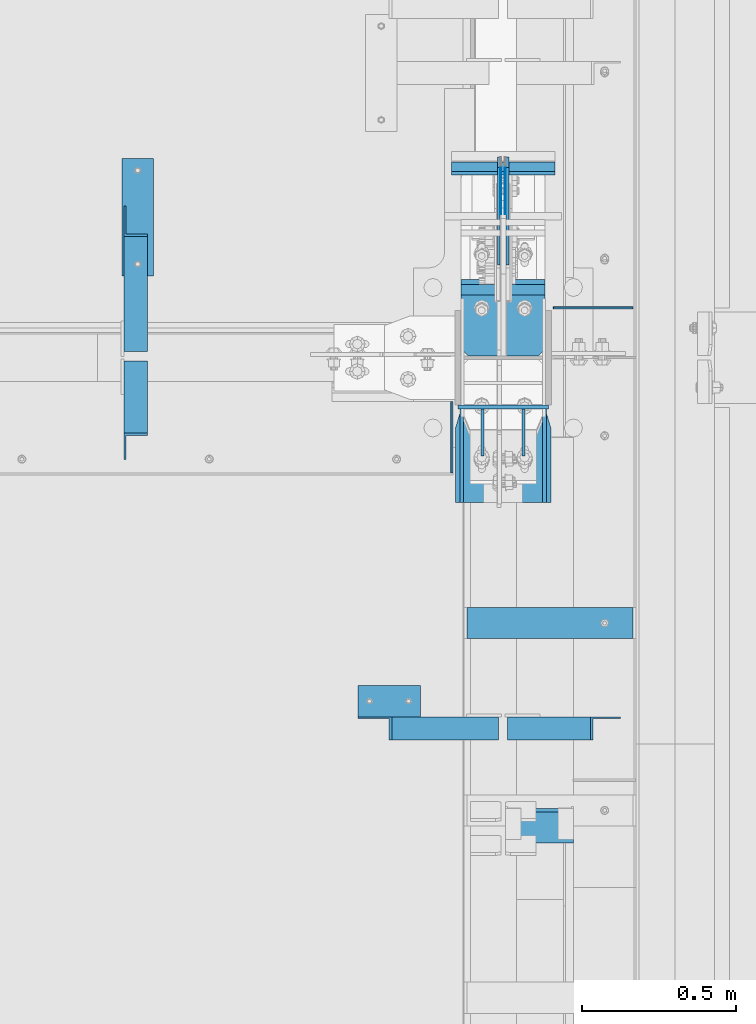
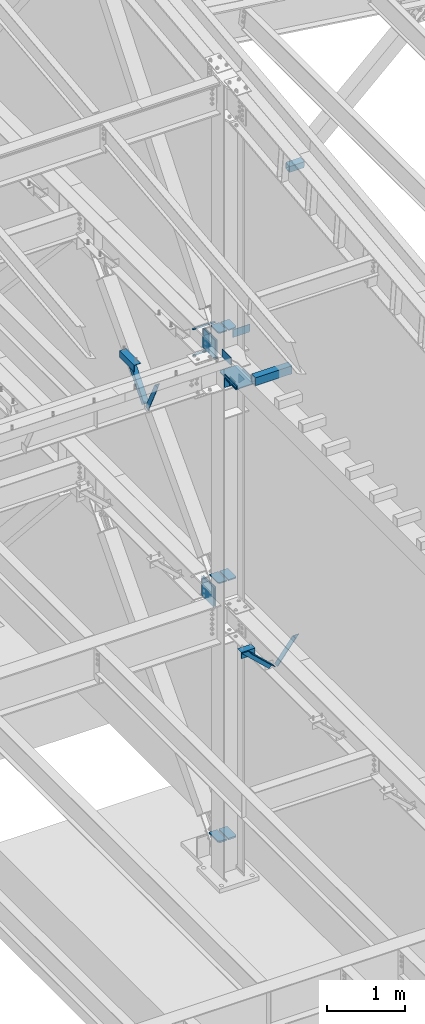
# One storey, part 843 of 1179: 26 beams, 4 members, 17 elements without a shape of their own.
"""IFC2X3 building model written with IfcOpenShell, lengths in millimetres."""

from ifc_helpers import new_model, si_unit, frame, origin_with_axes, place, context, subcontext, project, spatial, faceted_brep, material, type_object, element, aggregate, save


model = new_model("IFC2X3")

# Units and contexts
model_context = context("Model", 3, precision=1e-05, world=origin_with_axes())
body_context = subcontext(model_context, "Body", "Model", "MODEL_VIEW")
ifc_project = project(units=[si_unit("LENGTHUNIT", "METRE", prefix="MILLI"), si_unit("AREAUNIT", "SQUARE_METRE"), si_unit("VOLUMEUNIT", "CUBIC_METRE"), si_unit("MASSUNIT", "GRAM", prefix="KILO"), si_unit("TIMEUNIT", "SECOND"), si_unit("PLANEANGLEUNIT", "RADIAN"), si_unit("SOLIDANGLEUNIT", "STERADIAN"), si_unit("THERMODYNAMICTEMPERATUREUNIT", "DEGREE_CELSIUS"), si_unit("LUMINOUSINTENSITYUNIT", "LUMEN")], contexts=[model_context])

# Site, building, storey
site_placement = place(None, origin_with_axes())
site = spatial("IfcSite", under=ifc_project, at=site_placement, CompositionType="ELEMENT")
building_placement = place(site_placement, origin_with_axes())
building = spatial("IfcBuilding", under=site, at=building_placement, Name="Undefined", CompositionType="ELEMENT")
storey_placement = place(building_placement, origin_with_axes())
storey = spatial("IfcBuildingStorey", under=building, at=storey_placement, Name="Undefined", CompositionType="ELEMENT", Elevation=0.0)

# Assembly, member
assembly_1_placement = place(storey_placement, origin_with_axes())
assembly_1 = element("IfcElementAssembly", 1, at=assembly_1_placement, inside=storey, Name="ANGLE", AssemblyPlace="NOTDEFINED", PredefinedType="RIGID_FRAME")
ifc_material_1 = material(Name="STEEL/A36")
member_type = type_object("IfcMemberType", Name="L3X3X1/4", PredefinedType="NOTDEFINED")
member_1_placement = place(assembly_1_placement, frame((23112.4124995918, 27508.2, 8013.7), z_axis=(0.0, 0.7672237920886, -0.641379492074067), x_axis=(0.0, -0.641379492074066, -0.767223792088601)))
member_1 = element("IfcMember", 2, at=member_1_placement, type_object=member_type, material=ifc_material_1, Name="ANGLE", ObjectType="L3X3X1/4", context=body_context, shape_type="Brep", body=[
    faceted_brep([(52.5421123063024, 38.0999999999985, -38.0999999999967), (-11.159141226166, 38.0999999999985, 38.1000000000095), (634.651401994255, 38.0999999999985, 38.1000000003041), (634.651401994233, 38.0999999999985, -38.0999999997293), (-11.159141226166, 31.75, 38.1000000000095), (634.651401994255, 31.75, 38.1000000003041), (47.2336745119283, 31.75, -31.7499999999982), (634.651401994237, 31.75, -31.7499999997272), (47.2336745119283, -38.0999999999985, -31.7499999999982), (634.651401994237, -38.0999999999985, -31.7499999997272), (52.5421123063024, -38.0999999999985, -38.0999999999967), (634.651401994233, -38.0999999999985, -38.0999999997293)], [[[0, 1, 2, 3]], [[1, 4, 5, 2]], [[4, 6, 7, 5]], [[6, 8, 9, 7]], [[8, 10, 11, 9]], [[10, 0, 3, 11]], [[5, 7, 9, 11, 3, 2]], [[10, 8, 6, 4, 1, 0]]]),
])
aggregate(assembly_1, [member_1])

assembly_2_placement = place(storey_placement, origin_with_axes())
assembly_2 = element("IfcElementAssembly", 3, at=assembly_2_placement, inside=storey, Name="ANGLE", AssemblyPlace="NOTDEFINED", PredefinedType="RIGID_FRAME")
member_2_placement = place(assembly_2_placement, frame((23112.4124995918, 27005.4961357473, 7519.97080646429), z_axis=(0.0, -0.897509848200057, -0.440994413098296), x_axis=(0.0, -0.440994413098296, 0.897509848200057)))
member_2 = element("IfcMember", 4, at=member_2_placement, type_object=member_type, material=ifc_material_1, Name="ANGLE", ObjectType="L3X3X1/4", context=body_context, shape_type="Brep", body=[
    faceted_brep([(0.0, 38.0999999999985, -38.0999999999999), (0.0, 38.0999999999985, 38.0999999999999), (568.830616953598, 38.0999999999985, 38.0999999992709), (531.389496563324, 38.0999999999985, -38.1000000007189), (0.0, 31.75, 38.1000000000004), (568.830616953598, 31.75, 38.0999999992709), (0.0, 31.75, -31.75), (534.509589929181, 31.75, -31.7500000007203), (0.0, -38.0999999999985, -31.75), (534.509589929181, -38.0999999999985, -31.7500000007203), (0.0, -38.0999999999985, -38.0999999999999), (531.389496563324, -38.0999999999985, -38.1000000007189)], [[[0, 1, 2, 3]], [[1, 4, 5, 2]], [[4, 6, 7, 5]], [[6, 8, 9, 7]], [[8, 10, 11, 9]], [[10, 0, 3, 11]], [[5, 7, 9, 11, 3, 2]], [[10, 8, 6, 4, 1, 0]]]),
])
aggregate(assembly_2, [member_2])

assembly_3_placement = place(storey_placement, origin_with_axes())
assembly_3 = element("IfcElementAssembly", 5, at=assembly_3_placement, inside=storey, Name="ANGLE", AssemblyPlace="NOTDEFINED", PredefinedType="RIGID_FRAME")
member_3_placement = place(assembly_3_placement, frame((23812.1150890972, 25844.5, 4162.88757791506), z_axis=(0.0, -1.0, 0.0), x_axis=(0.729484494811633, 0.0, -0.683997347823379)))
member_3 = element("IfcMember", 6, at=member_3_placement, type_object=member_type, material=ifc_material_1, Name="ANGLE", ObjectType="L3X3X1/4", context=body_context, shape_type="Brep", body=[
    faceted_brep([(148.072119708857, 38.1000000000204, -38.0999999999985), (148.072119708857, 38.1000000000204, 38.0999999999985), (623.824460863128, 38.1000000000349, 38.0999999999985), (623.824460863128, 38.1000000000349, -38.0999999999985), (141.299832423247, 31.7500000000182, 38.0999999999985), (623.824460863128, 31.7500000000291, 38.0999999999985), (141.299832423247, 31.7500000000182, -31.75), (623.824460863128, 31.7500000000291, -31.75), (66.8046722815307, -38.1000000000095, -31.75), (623.824460863132, -38.0999999999913, -31.75), (66.8046722815307, -38.1000000000095, -38.0999999999985), (623.824460863132, -38.0999999999913, -38.0999999999985)], [[[0, 1, 2, 3]], [[1, 4, 5, 2]], [[4, 6, 7, 5]], [[6, 8, 9, 7]], [[8, 10, 11, 9]], [[10, 0, 3, 11]], [[5, 7, 9, 11, 3, 2]], [[10, 8, 6, 4, 1, 0]]]),
])
aggregate(assembly_3, [member_3])

assembly_4_placement = place(storey_placement, origin_with_axes())
assembly_4 = element("IfcElementAssembly", 7, at=assembly_4_placement, inside=storey, Name="ANGLE", AssemblyPlace="NOTDEFINED", PredefinedType="RIGID_FRAME")
member_4_placement = place(assembly_4_placement, frame((24352.3014298031, 25844.5, 3731.6636484264), z_axis=(0.0, -1.0, 0.0), x_axis=(0.614083067285056, 0.0, 0.789241399366365)))
member_4 = element("IfcMember", 8, at=member_4_placement, type_object=member_type, material=ifc_material_1, Name="ANGLE", ObjectType="L3X3X1/4", context=body_context, shape_type="Brep", body=[
    faceted_brep([(0.0, 38.0999999999985, -38.0999999999999), (0.0, 38.0999999999985, 38.0999999999999), (439.713105507173, 38.1000000000386, 38.0999999999985), (439.713105507173, 38.1000000000386, -38.0999999999985), (0.0, 31.75, 38.1000000000004), (444.653834009747, 31.7500000000473, 38.0999999999985), (0.0, 31.75, -31.75), (444.653834009747, 31.7500000000473, -31.75), (0.0, -38.0999999999985, -31.75), (499.001847538042, -38.0999999998749, -31.75), (0.0, -38.0999999999985, -38.0999999999999), (499.001847538042, -38.0999999998749, -38.0999999999985)], [[[0, 1, 2, 3]], [[1, 4, 5, 2]], [[4, 6, 7, 5]], [[6, 8, 9, 7]], [[8, 10, 11, 9]], [[10, 0, 3, 11]], [[5, 7, 9, 11, 3, 2]], [[10, 8, 6, 4, 1, 0]]]),
])
aggregate(assembly_4, [member_4])

# Assembly, beams
assembly_5_placement = place(storey_placement, origin_with_axes())
assembly_5 = element("IfcElementAssembly", 9, at=assembly_5_placement, inside=storey, Name="BEAM", AssemblyPlace="NOTDEFINED", PredefinedType="RIGID_FRAME")
ifc_material_2 = material(Name="STEEL/A572-GR.50")
beam_type_1 = type_object("IfcBeamType", PredefinedType="NOTDEFINED")
beam_1_placement = place(assembly_5_placement, frame((24307.8000366209, 27677.4467233733, 7589.8375), z_axis=(-1.0, 0.0, 0.0), x_axis=(0.0, -1.0, 0.0)))
beam_1 = element("IfcBeam", 10, at=beam_1_placement, type_object=beam_type_1, material=ifc_material_2, Name="PLATE", context=body_context, shape_type="Brep", body=[
    faceted_brep([(0.0, 4.76249999999982, -168.275000000001), (0.0, 4.76250000000073, 168.275), (31.75, 4.76249999999982, 168.275000000001), (31.75, 4.76249999999982, -168.275000000001), (0.0, -4.76250000000073, 168.275), (31.75, -4.76249999999982, 168.275000000001), (0.0, -4.76249999999982, -168.275000000001), (31.75, -4.76249999999982, -168.275000000001)], [[[0, 1, 2, 3]], [[1, 4, 5, 2]], [[4, 6, 7, 5]], [[6, 0, 3, 7]], [[5, 7, 3, 2]], [[6, 4, 1, 0]]]),
])
beam_2_placement = place(assembly_5_placement, frame((24307.8000366209, 27688.5588209119, 7989.4905), z_axis=(-1.0, 0.0, 0.0), x_axis=(0.0, -1.0, 0.0)))
beam_2 = element("IfcBeam", 11, at=beam_2_placement, type_object=beam_type_1, material=ifc_material_2, Name="PLATE", context=body_context, shape_type="Brep", body=[
    faceted_brep([(0.0, 4.76249999999982, -168.275000000001), (0.0, 4.76250000000073, 168.275), (31.75, 4.76249999999982, 168.275000000001), (31.75, 4.76249999999982, -168.275000000001), (0.0, -4.76250000000073, 168.275), (31.75, -4.76249999999982, 168.275000000001), (0.0, -4.76249999999982, -168.275000000001), (31.75, -4.76249999999982, -168.275000000001)], [[[0, 1, 2, 3]], [[1, 4, 5, 2]], [[4, 6, 7, 5]], [[6, 0, 3, 7]], [[5, 7, 3, 2]], [[6, 4, 1, 0]]]),
])

assembly_6_placement = place(storey_placement, origin_with_axes())
assembly_6 = element("IfcElementAssembly", 12, at=assembly_6_placement, inside=storey, Name="COLUMN", AssemblyPlace="NOTDEFINED", PredefinedType="RIGID_FRAME")
beam_type_2 = type_object("IfcBeamType", PredefinedType="NOTDEFINED")
beam_3_placement = place(assembly_6_placement, frame((24160.1625, 26890.6625, 7616.82500000912), z_axis=(0.0, 0.0, 1.0), x_axis=(1.0, 0.0, 0.0)))
beam_3 = element("IfcBeam", 13, at=beam_3_placement, type_object=beam_type_2, material=ifc_material_1, Name="PLATE", context=body_context, shape_type="Brep", body=[
    faceted_brep([(-7.27595761418343e-12, 6.35000000000036, -76.1999999999971), (0.0, 6.35000000000036, 76.2000000000044), (295.274999999994, 6.34999999999854, 76.2000000000007), (295.274999999994, 6.34999999999854, -76.2000000000007), (0.0, -6.35000000000036, 76.2000000000044), (295.274999999994, -6.34999999999854, 76.2000000000007), (7.27595761418343e-12, -6.35000000000036, -76.1999999999971), (295.274999999994, -6.34999999999854, -76.2000000000007)], [[[0, 1, 2, 3]], [[1, 4, 5, 2]], [[4, 6, 7, 5]], [[6, 0, 3, 7]], [[5, 7, 3, 2]], [[6, 4, 1, 0]]]),
])
beam_type_3 = type_object("IfcBeamType", PredefinedType="NOTDEFINED")
beam_4_placement = place(assembly_6_placement, frame((24381.619, 27288.7322991996, 4353.49928057187), z_axis=(1.0, 0.0, 0.0), x_axis=(0.0, -1.0, 0.0)))
beam_4 = element("IfcBeam", 14, at=beam_4_placement, type_object=beam_type_3, material=ifc_material_2, Name="PLATE", context=body_context, shape_type="Brep", body=[
    faceted_brep([(209.157299199604, -9.52499999999964, 62.7065000000002), (231.382299199602, -9.52499999999964, 40.4815000000017), (231.382299199602, 9.52499999999964, 40.4815000000017), (209.157299199604, 9.52499999999964, 62.7065000000002), (231.382299199602, 9.52499999999964, -62.7065000000002), (6.18456397205591e-11, 9.52499999999964, -62.7065000000084), (0.0, 9.52499999999964, 62.7065000000002), (0.0, -9.52499999999964, 62.7065000000002), (6.18456397205591e-11, -9.52499999999964, -62.7065000000084), (231.382299199602, -9.52499999999964, -62.7065000000002)], [[[0, 1, 2, 3]], [[4, 5, 6, 3, 2]], [[6, 7, 0, 3]], [[7, 8, 9, 1, 0]], [[8, 5, 4, 9]], [[9, 4, 2, 1]], [[8, 7, 6, 5]]]),
])
beam_5_placement = place(assembly_6_placement, frame((24233.981, 27288.7322991996, 4353.49928057187), z_axis=(-1.0, 0.0, 0.0), x_axis=(0.0, -1.0, 0.0)))
beam_5 = element("IfcBeam", 15, at=beam_5_placement, type_object=beam_type_3, material=ifc_material_2, Name="PLATE", context=body_context, shape_type="Brep", body=[
    faceted_brep([(209.157299199604, -9.52499999999964, 62.7065000000002), (231.382299199602, -9.52499999999964, 40.4815000000017), (231.382299199602, 9.52499999999964, 40.4815000000017), (209.157299199604, 9.52499999999964, 62.7065000000002), (231.382299199602, 9.52499999999964, -62.7065000000002), (6.18456397205591e-11, 9.52499999999964, -62.7065000000084), (0.0, 9.52499999999964, 62.7065000000002), (0.0, -9.52499999999964, 62.7065000000002), (6.18456397205591e-11, -9.52499999999964, -62.7065000000084), (231.382299199602, -9.52499999999964, -62.7065000000002)], [[[0, 1, 2, 3]], [[4, 5, 6, 3, 2]], [[6, 7, 0, 3]], [[7, 8, 9, 1, 0]], [[8, 5, 4, 9]], [[9, 4, 2, 1]], [[8, 7, 6, 5]]]),
])
beam_type_4 = type_object("IfcBeamType", PredefinedType="NOTDEFINED")
beam_6_placement = place(assembly_6_placement, frame((24234.775, 27057.35, 8286.54339140945), z_axis=(-1.0, 0.0, 0.0), x_axis=(0.0, 1.0, 0.0)))
beam_6 = element("IfcBeam", 16, at=beam_6_placement, type_object=beam_type_4, material=ifc_material_2, Name="PLATE", context=body_context, shape_type="Brep", body=[
    faceted_brep([(1.81898940354586e-11, -9.52499999999782, 41.2750000000015), (22.2250000000204, -9.525000000006, 63.5), (22.2249999999913, 9.52499999999327, 63.5), (-7.27595761418343e-12, 9.52500000000146, 41.2750000000015), (198.4375, 9.52499999999964, 63.5), (198.4375, 9.52499999999964, -63.5), (0.0, 9.52500000000146, -63.5), (198.4375, -9.52499999999964, 63.5), (0.0, -9.52500000000146, -63.5), (198.4375, -9.52499999999964, -63.5)], [[[0, 1, 2, 3]], [[4, 5, 6, 3, 2]], [[7, 4, 2, 1]], [[8, 9, 7, 1, 0]], [[8, 6, 5, 9]], [[7, 9, 5, 4]], [[6, 8, 0, 3]]]),
])
beam_7_placement = place(assembly_6_placement, frame((24380.825, 27057.35, 8286.54339140945), z_axis=(-1.0, 0.0, 0.0), x_axis=(0.0, 1.0, 0.0)))
beam_7 = element("IfcBeam", 17, at=beam_7_placement, type_object=beam_type_4, material=ifc_material_2, Name="PLATE", context=body_context, shape_type="Brep", body=[
    faceted_brep([(22.2250000000204, -9.525000000006, -63.5), (1.81898940354586e-11, -9.52499999999782, -41.2750000000015), (-7.27595761418343e-12, 9.52500000000146, -41.2750000000015), (22.2249999999913, 9.52499999999327, -63.5), (0.0, 9.52500000000146, 63.5), (198.4375, 9.52499999999964, 63.5), (198.4375, 9.52499999999964, -63.5), (0.0, -9.52500000000146, 63.5), (198.4375, -9.52499999999964, 63.5), (198.4375, -9.52499999999964, -63.5)], [[[0, 1, 2, 3]], [[4, 5, 6, 3, 2]], [[4, 7, 8, 5]], [[9, 8, 7, 1, 0]], [[6, 9, 0, 3]], [[8, 9, 6, 5]], [[7, 4, 2, 1]]]),
])

# Assembly, beam
assembly_7_placement = place(storey_placement, origin_with_axes())
assembly_7 = element("IfcElementAssembly", 18, at=assembly_7_placement, inside=storey, Name="ANGLE", AssemblyPlace="NOTDEFINED", PredefinedType="RIGID_FRAME")
beam_type_5 = type_object("IfcBeamType", Name="L4X4X1/4", PredefinedType="NOTDEFINED")
beam_8_placement = place(assembly_7_placement, frame((23118.7624995918, 27317.6213553416, 7962.9), z_axis=(1.0, 0.0, 0.0), x_axis=(0.0, 1.0, 0.0)))
beam_8 = element("IfcBeam", 19, at=beam_8_placement, type_object=beam_type_5, material=ifc_material_1, Name="ANGLE", ObjectType="L4X4X1/4", context=body_context, shape_type="Brep", body=[
    faceted_brep([(1.90993887372315e-11, 50.8000000000002, -50.8000000000002), (1.90993887372315e-11, 50.8000000000002, 50.8000000000002), (381.0, 50.8000000000002, 50.7999999999993), (381.0, 50.8000000000002, -50.7999999999993), (0.0, 44.4500000000007, 50.8000000000002), (381.0, 44.4499999999998, 50.7999999999993), (0.0, 44.4500000000007, -44.4499999999998), (381.0, 44.4499999999998, -44.4500000000007), (0.0, -50.7999999999993, -44.4499999999998), (381.0, -50.8000000000002, -44.4500000000007), (-1.81898940354586e-11, -50.7999999999997, -50.8000000000002), (381.0, -50.8000000000002, -50.7999999999993)], [[[0, 1, 2, 3]], [[1, 4, 5, 2]], [[4, 6, 7, 5]], [[6, 8, 9, 7]], [[8, 10, 11, 9]], [[10, 0, 3, 11]], [[5, 7, 9, 11, 3, 2]], [[10, 8, 6, 4, 1, 0]]]),
])
aggregate(assembly_7, [beam_8])

assembly_8_placement = place(storey_placement, origin_with_axes())
assembly_8 = element("IfcElementAssembly", 20, at=assembly_8_placement, inside=storey, Name="ANGLE", AssemblyPlace="NOTDEFINED", PredefinedType="RIGID_FRAME")
beam_9_placement = place(assembly_8_placement, frame((23834.8036446584, 25933.4, 4051.3), z_axis=(0.0, 0.0, -1.0), x_axis=(1.0, 0.0, 0.0)))
beam_9 = element("IfcBeam", 21, at=beam_9_placement, type_object=beam_type_5, material=ifc_material_1, Name="ANGLE", ObjectType="L4X4X1/4", context=body_context, shape_type="Brep", body=[
    faceted_brep([(1.90993887372315e-11, 50.8000000000002, -50.8000000000002), (1.90993887372315e-11, 50.8000000000002, 50.8000000000002), (203.200000000001, 50.7999999999993, 50.8000000000002), (203.200000000001, 50.7999999999993, -50.8000000000002), (0.0, 44.4500000000007, 50.8000000000002), (203.200000000001, 44.4500000000007, 50.8000000000002), (0.0, 44.4500000000007, -44.4499999999998), (203.200000000001, 44.4500000000007, -44.4499999999998), (0.0, -50.7999999999993, -44.4499999999998), (203.200000000001, -50.7999999999993, -44.4499999999998), (-1.81898940354586e-11, -50.7999999999997, -50.8000000000002), (203.200000000001, -50.7999999999993, -50.8000000000002)], [[[0, 1, 2, 3]], [[1, 4, 5, 2]], [[4, 6, 7, 5]], [[6, 8, 9, 7]], [[8, 10, 11, 9]], [[10, 0, 3, 11]], [[5, 7, 9, 11, 3, 2]], [[10, 8, 6, 4, 1, 0]]]),
])
aggregate(assembly_8, [beam_9])

assembly_9_placement = place(storey_placement, origin_with_axes())
assembly_9 = element("IfcElementAssembly", 22, at=assembly_9_placement, inside=storey, Name="BEAM", AssemblyPlace="NOTDEFINED", PredefinedType="RIGID_FRAME")
beam_type_6 = type_object("IfcBeamType", PredefinedType="NOTDEFINED")
beam_10_placement = place(assembly_9_placement, frame((24141.113, 26676.35, 8083.55000610352), z_axis=(0.0, 0.0, 1.0), x_axis=(0.0, 1.0, 0.0)))
beam_10 = element("IfcBeam", 23, at=beam_10_placement, type_object=beam_type_6, material=ifc_material_1, Name="PLATE", context=body_context, shape_type="Brep", body=[
    faceted_brep([(0.0, 3.17499999999995, -44.4499999999998), (19.0499999999993, 3.17499999999995, -63.5), (19.0499999999993, -3.17499999999995, -63.5), (0.0, -3.17499999999995, -44.4499999999998), (0.0, 3.17499999999927, 63.5), (231.775012187987, 3.17499999989741, 63.5), (231.775012187987, 3.17499999989741, -63.5), (0.0, -3.17499999999927, 63.5), (231.775012187984, -3.17500000010114, 63.5), (231.775012187984, -3.17500000010114, -63.5)], [[[0, 1, 2, 3]], [[4, 5, 6, 1, 0]], [[4, 7, 8, 5]], [[9, 8, 7, 3, 2]], [[6, 9, 2, 1]], [[8, 9, 6, 5]], [[7, 4, 0, 3]]]),
])
aggregate(assembly_9, [beam_10])

# Beam
beam_type_7 = type_object("IfcBeamType", PredefinedType="NOTDEFINED")
beam_11_placement = place(assembly_5_placement, frame((24300.65625, 27669.5088209119, 7804.15), z_axis=(0.0, 0.0, -1.0), x_axis=(0.0, -1.0, 0.0)))
beam_11 = element("IfcBeam", 24, at=beam_11_placement, type_object=beam_type_7, material=ifc_material_2, Name="PLATE", context=body_context, shape_type="Brep", body=[
    faceted_brep([(0.0, 1.58750000000146, -152.4), (0.0, 1.58750000000146, 152.4), (152.400000000009, 1.58750000000146, 152.4), (152.400000000009, 1.58750000000146, -152.4), (0.0, -1.58750000000146, 152.4), (152.400000000009, -1.58750000000146, 152.4), (0.0, -1.58750000000146, -152.4), (152.400000000009, -1.58750000000146, -152.4)], [[[0, 1, 2, 3]], [[1, 4, 5, 2]], [[4, 6, 7, 5]], [[6, 0, 3, 7]], [[5, 7, 3, 2]], [[6, 4, 1, 0]]]),
])

beam_12_placement = place(assembly_5_placement, frame((24314.94375, 27669.5088209119, 7804.15), z_axis=(0.0, 0.0, -1.0), x_axis=(0.0, -1.0, 0.0)))
beam_12 = element("IfcBeam", 25, at=beam_12_placement, type_object=beam_type_7, material=ifc_material_2, Name="PLATE", context=body_context, shape_type="Brep", body=[
    faceted_brep([(0.0, 1.58750000000146, -152.4), (0.0, 1.58750000000146, 152.4), (152.400000000009, 1.58750000000146, 152.4), (152.400000000009, 1.58750000000146, -152.4), (0.0, -1.58750000000146, 152.4), (152.400000000009, -1.58750000000146, 152.4), (0.0, -1.58750000000146, -152.4), (152.400000000009, -1.58750000000146, -152.4)], [[[0, 1, 2, 3]], [[1, 4, 5, 2]], [[4, 6, 7, 5]], [[6, 0, 3, 7]], [[5, 7, 3, 2]], [[6, 4, 1, 0]]]),
])

beam_type_8 = type_object("IfcBeamType", PredefinedType="NOTDEFINED")
beam_13_placement = place(assembly_5_placement, frame((24471.3125128158, 27212.9249996176, 8085.1375), z_axis=(0.0, 0.0, 1.0), x_axis=(1.0, 0.0, 0.0)))
beam_13 = element("IfcBeam", 26, at=beam_13_placement, type_object=beam_type_8, material=ifc_material_1, Name="PLATE", context=body_context, shape_type="Brep", body=[
    faceted_brep([(258.762494772014, -3.17499999977008, -42.8625000000002), (239.712494772015, -3.17499999978463, -61.9125000000004), (239.712494772011, 3.17500000021391, -61.9125000000004), (258.762494772011, 3.1750000002321, -42.8625000000002), (0.0, 3.17499999999927, -61.9125000000004), (0.0, 3.17499999999927, 61.9125000000004), (258.762494772011, 3.1750000002321, 61.9125000000004), (3.63797880709171e-12, -3.17499999999927, 61.9125000000004), (258.762494772014, -3.17499999977008, 61.9125000000004), (3.63797880709171e-12, -3.17499999999927, -61.9125000000004)], [[[0, 1, 2, 3]], [[4, 5, 6, 3, 2]], [[5, 7, 8, 6]], [[8, 7, 9, 1, 0]], [[9, 4, 2, 1]], [[6, 8, 0, 3]], [[9, 7, 5, 4]]]),
])

aggregate(assembly_5, [beam_1, beam_11, beam_12, beam_13, beam_2])

# Assembly, beam
assembly_10_placement = place(storey_placement, origin_with_axes())
assembly_10 = element("IfcElementAssembly", 27, at=assembly_10_placement, inside=storey, Name="PLATE", AssemblyPlace="NOTDEFINED", PredefinedType="RIGID_FRAME")
beam_type_9 = type_object("IfcBeamType", PredefinedType="NOTDEFINED")
beam_14_placement = place(assembly_10_placement, frame((24293.5125, 27703.683001131, 3892.55), z_axis=(0.0, 0.0, -1.0), x_axis=(0.0, -1.0, 0.0)))
beam_14 = element("IfcBeam", 28, at=beam_14_placement, type_object=beam_type_9, material=ifc_material_2, Name="PLATE", context=body_context, shape_type="Brep", body=[
    faceted_brep([(0.0, 4.76250000000073, -152.4), (0.0, 4.76250000000073, 152.4), (317.5, 4.76250000000073, 152.4), (317.5, 4.76250000000073, -152.4), (0.0, -4.76250000000073, 152.4), (317.5, -4.76250000000073, 152.4), (0.0, -4.76250000000073, -152.4), (317.5, -4.76250000000073, -152.4)], [[[0, 1, 2, 3]], [[1, 4, 5, 2]], [[4, 6, 7, 5]], [[6, 0, 3, 7]], [[5, 7, 3, 2]], [[6, 4, 1, 0]]]),
])
aggregate(assembly_10, [beam_14])

assembly_11_placement = place(storey_placement, origin_with_axes())
assembly_11 = element("IfcElementAssembly", 29, at=assembly_11_placement, inside=storey, Name="PLATE", AssemblyPlace="NOTDEFINED", PredefinedType="RIGID_FRAME")
beam_15_placement = place(assembly_11_placement, frame((24322.0875, 27386.183001131, 3892.55), z_axis=(0.0, 0.0, -1.0), x_axis=(0.0, 1.0, 0.0)))
beam_15 = element("IfcBeam", 30, at=beam_15_placement, type_object=beam_type_9, material=ifc_material_2, Name="PLATE", context=body_context, shape_type="Brep", body=[
    faceted_brep([(0.0, 4.76250000000073, -152.4), (0.0, 4.76250000000073, 152.4), (317.5, 4.76250000000073, 152.4), (317.5, 4.76250000000073, -152.4), (0.0, -4.76250000000073, 152.4), (317.5, -4.76250000000073, 152.4), (0.0, -4.76250000000073, -152.4), (317.5, -4.76250000000073, -152.4)], [[[0, 1, 2, 3]], [[1, 4, 5, 2]], [[4, 6, 7, 5]], [[6, 0, 3, 7]], [[5, 7, 3, 2]], [[6, 4, 1, 0]]]),
])
aggregate(assembly_11, [beam_15])

assembly_12_placement = place(storey_placement, origin_with_axes())
assembly_12 = element("IfcElementAssembly", 31, at=assembly_12_placement, inside=storey, Name="PLATE", AssemblyPlace="NOTDEFINED", PredefinedType="RIGID_FRAME")
beam_16_placement = place(assembly_12_placement, frame((24293.5127863882, 27669.5088209119, 7804.15), z_axis=(0.0, 0.0, -1.0), x_axis=(0.0, -1.0, 0.0)))
beam_16 = element("IfcBeam", 32, at=beam_16_placement, type_object=beam_type_9, material=ifc_material_2, Name="PLATE", context=body_context, shape_type="Brep", body=[
    faceted_brep([(0.0, 4.76250000000073, -152.4), (0.0, 4.76250000000073, 152.4), (317.5, 4.76250000000073, 152.4), (317.5, 4.76250000000073, -152.4), (0.0, -4.76250000000073, 152.4), (317.5, -4.76250000000073, 152.4), (0.0, -4.76250000000073, -152.4), (317.5, -4.76250000000073, -152.4)], [[[0, 1, 2, 3]], [[1, 4, 5, 2]], [[4, 6, 7, 5]], [[6, 0, 3, 7]], [[5, 7, 3, 2]], [[6, 4, 1, 0]]]),
])
aggregate(assembly_12, [beam_16])

assembly_13_placement = place(storey_placement, origin_with_axes())
assembly_13 = element("IfcElementAssembly", 33, at=assembly_13_placement, inside=storey, Name="PLATE", AssemblyPlace="NOTDEFINED", PredefinedType="RIGID_FRAME")
beam_17_placement = place(assembly_13_placement, frame((24322.0872136118, 27352.0088209119, 7804.15), z_axis=(0.0, 0.0, -1.0), x_axis=(0.0, 1.0, 0.0)))
beam_17 = element("IfcBeam", 34, at=beam_17_placement, type_object=beam_type_9, material=ifc_material_2, Name="PLATE", context=body_context, shape_type="Brep", body=[
    faceted_brep([(0.0, 4.76250000000073, -152.4), (0.0, 4.76250000000073, 152.4), (317.5, 4.76250000000073, 152.4), (317.5, 4.76250000000073, -152.4), (0.0, -4.76250000000073, 152.4), (317.5, -4.76250000000073, 152.4), (0.0, -4.76250000000073, -152.4), (317.5, -4.76250000000073, -152.4)], [[[0, 1, 2, 3]], [[1, 4, 5, 2]], [[4, 6, 7, 5]], [[6, 0, 3, 7]], [[5, 7, 3, 2]], [[6, 4, 1, 0]]]),
])
aggregate(assembly_13, [beam_17])

# Beam
beam_type_10 = type_object("IfcBeamType", PredefinedType="NOTDEFINED")
beam_18_placement = place(assembly_6_placement, frame((24172.8625, 26579.5125, 7727.95000000912), z_axis=(0.0, 0.0, 1.0), x_axis=(0.0, 1.0, 0.0)))
beam_18 = element("IfcBeam", 35, at=beam_18_placement, type_object=beam_type_10, material=ifc_material_1, Name="PLATE", context=body_context, shape_type="Brep", body=[
    faceted_brep([(0.0, 6.34999999999854, -19.0499999999993), (0.0, 6.35000000000036, 19.0499999999993), (317.5, 6.34999999999854, 19.0499999999993), (317.5, 6.34999999999854, -19.0499999999993), (0.0, -6.35000000000036, 19.0499999999993), (317.5, -6.34999999999854, 19.0499999999993), (0.0, -6.34999999999854, -19.0499999999993), (317.5, -6.34999999999854, -19.0499999999993)], [[[0, 1, 2, 3]], [[1, 4, 5, 2]], [[4, 6, 7, 5]], [[6, 0, 3, 7]], [[5, 7, 3, 2]], [[6, 4, 1, 0]]]),
])

beam_19_placement = place(assembly_6_placement, frame((24442.7375, 26579.5125, 7727.95000000912), z_axis=(0.0, 0.0, 1.0), x_axis=(0.0, 1.0, 0.0)))
beam_19 = element("IfcBeam", 36, at=beam_19_placement, type_object=beam_type_10, material=ifc_material_1, Name="PLATE", context=body_context, shape_type="Brep", body=[
    faceted_brep([(0.0, 6.34999999999854, -19.0499999999993), (0.0, 6.35000000000036, 19.0499999999993), (317.5, 6.34999999999854, 19.0499999999993), (317.5, 6.34999999999854, -19.0499999999993), (0.0, -6.35000000000036, 19.0499999999993), (317.5, -6.34999999999854, 19.0499999999993), (0.0, -6.34999999999854, -19.0499999999993), (317.5, -6.34999999999854, -19.0499999999993)], [[[0, 1, 2, 3]], [[1, 4, 5, 2]], [[4, 6, 7, 5]], [[6, 0, 3, 7]], [[5, 7, 3, 2]], [[6, 4, 1, 0]]]),
])

beam_type_11 = type_object("IfcBeamType", PredefinedType="NOTDEFINED")
beam_20_placement = place(assembly_6_placement, frame((24241.125, 26731.9125, 7616.82500000912), z_axis=(0.0, 0.0, 1.0), x_axis=(0.0, 1.0, 0.0)))
beam_20 = element("IfcBeam", 37, at=beam_20_placement, type_object=beam_type_11, material=ifc_material_1, Name="PLATE", context=body_context, shape_type="Brep", body=[
    faceted_brep([(152.4, -4.76249999999709, 76.2), (152.4, -4.76249999999709, -76.2), (152.4, 4.76249999999709, -76.2), (152.4, 4.76249999999709, 76.2), (0.0, 4.76249999999982, 76.1999999999971), (0.0, -4.76249999999982, 76.1999999999971)], [[[0, 1, 2, 3]], [[3, 2, 4]], [[4, 5, 0, 3]], [[0, 5, 1]], [[4, 2, 1, 5]]]),
])

beam_21_placement = place(assembly_6_placement, frame((24374.475, 26731.9125, 7616.82500000912), z_axis=(0.0, 0.0, 1.0), x_axis=(0.0, 1.0, 0.0)))
beam_21 = element("IfcBeam", 38, at=beam_21_placement, type_object=beam_type_11, material=ifc_material_1, Name="PLATE", context=body_context, shape_type="Brep", body=[
    faceted_brep([(152.4, -4.76249999999709, 76.2), (152.4, -4.76249999999709, -76.2), (152.4, 4.76249999999709, -76.2), (152.4, 4.76249999999709, 76.2), (0.0, 4.76249999999982, 76.1999999999971), (0.0, -4.76249999999982, 76.1999999999971)], [[[0, 1, 2, 3]], [[3, 2, 4]], [[4, 5, 0, 3]], [[0, 5, 1]], [[4, 2, 1, 5]]]),
])

beam_type_12 = type_object("IfcBeamType", PredefinedType="NOTDEFINED")
beam_22_placement = place(assembly_6_placement, frame((24307.8, 26579.5125, 7700.96250000912), z_axis=(1.0, 0.0, 0.0), x_axis=(0.0, 1.0, 0.0)))
beam_22 = element("IfcBeam", 39, at=beam_22_placement, type_object=beam_type_12, material=ifc_material_1, Name="PLATE", context=body_context, shape_type="Brep", body=[
    faceted_brep([(465.137499999997, -7.9375, -114.300000762945), (442.912499999999, -7.9375, -136.525000762944), (442.912500000006, 7.9375, -136.525000762944), (465.137500000004, 7.9375, -114.300000762945), (465.137500000004, 7.9375, 114.300000762938), (442.912500000006, 7.9375, 136.525000762937), (442.912499999999, -7.9375, 136.525000762937), (465.137499999997, -7.9375, 114.300000762938), (241.300006103491, -7.9375, -155.575000000001), (241.300006103491, 7.9375, -155.575000000001), (304.799990844724, 7.9375, -136.525000762944), (304.799990844724, -7.9375, -136.525000762944), (0.0, -7.9375, -155.575000000001), (0.0, -7.9375, 155.575000000001), (0.0, 7.9375, 155.575000000001), (0.0, 7.9375, -155.575000000001), (241.300006103513, -7.9375, 155.575000000001), (241.300006103513, 7.9375, 155.575000000001), (304.799990844724, -7.9375, 136.525000762937), (304.799990844724, 7.9375, 136.525000762937)], [[[0, 1, 2, 3]], [[4, 5, 6, 7]], [[8, 9, 10, 11]], [[11, 10, 2, 1]], [[12, 13, 14, 15]], [[14, 13, 16, 17]], [[18, 19, 17, 16]], [[19, 18, 6, 5]], [[4, 7, 0, 3]], [[10, 9, 15, 14, 17, 19, 5, 4, 3, 2]], [[12, 15, 9, 8]], [[7, 6, 18, 16, 13, 12, 8, 11, 1, 0]]]),
])

aggregate(assembly_6, [beam_6, beam_7, beam_4, beam_5, beam_18, beam_20, beam_19, beam_21, beam_3, beam_22])

# Assembly, beam
assembly_14_placement = place(storey_placement, origin_with_axes())
assembly_14 = element("IfcElementAssembly", 40, at=assembly_14_placement, inside=storey, Name="PLATE", AssemblyPlace="NOTDEFINED", PredefinedType="RIGID_FRAME")
beam_type_13 = type_object("IfcBeamType", PredefinedType="NOTDEFINED")
beam_23_placement = place(assembly_14_placement, frame((24381.619, 27305.9695020474, 285.099397473982), z_axis=(1.0, 0.0, 0.0), x_axis=(0.0, -1.0, 0.0)))
beam_23 = element("IfcBeam", 41, at=beam_23_placement, type_object=beam_type_13, material=ifc_material_2, Name="PLATE", context=body_context, shape_type="Brep", body=[
    faceted_brep([(226.394502047388, -12.7, 62.7065000000002), (248.619502047386, -12.7, 40.4815000000017), (248.619502047386, 12.7, 40.4815000000017), (226.394502047388, 12.7, 62.7065000000002), (248.619502047386, 12.7, -62.7065000000002), (0.0, 12.7, -62.7065000000002), (0.0, 12.7, 62.7065000000002), (0.0, -12.7, 62.7065000000002), (0.0, -12.7, -62.7065000000002), (248.619502047386, -12.7, -62.7065000000002)], [[[0, 1, 2, 3]], [[4, 5, 6, 3, 2]], [[6, 7, 0, 3]], [[7, 8, 9, 1, 0]], [[8, 5, 4, 9]], [[9, 4, 2, 1]], [[8, 7, 6, 5]]]),
])
aggregate(assembly_14, [beam_23])

assembly_15_placement = place(storey_placement, origin_with_axes())
assembly_15 = element("IfcElementAssembly", 42, at=assembly_15_placement, inside=storey, Name="PLATE", AssemblyPlace="NOTDEFINED", PredefinedType="RIGID_FRAME")
beam_24_placement = place(assembly_15_placement, frame((24233.981, 27305.9695020474, 285.099397473982), z_axis=(-1.0, 0.0, 0.0), x_axis=(0.0, -1.0, 0.0)))
beam_24 = element("IfcBeam", 43, at=beam_24_placement, type_object=beam_type_13, material=ifc_material_2, Name="PLATE", context=body_context, shape_type="Brep", body=[
    faceted_brep([(226.394502047388, -12.7, 62.7065000000002), (248.619502047386, -12.7, 40.4815000000017), (248.619502047386, 12.7, 40.4815000000017), (226.394502047388, 12.7, 62.7065000000002), (248.619502047386, 12.7, -62.7065000000002), (0.0, 12.7, -62.7065000000002), (0.0, 12.7, 62.7065000000002), (0.0, -12.7, 62.7065000000002), (0.0, -12.7, -62.7065000000002), (248.619502047386, -12.7, -62.7065000000002)], [[[0, 1, 2, 3]], [[4, 5, 6, 3, 2]], [[6, 7, 0, 3]], [[7, 8, 9, 1, 0]], [[8, 5, 4, 9]], [[9, 4, 2, 1]], [[8, 7, 6, 5]]]),
])
aggregate(assembly_15, [beam_24])

assembly_16_placement = place(storey_placement, origin_with_axes())
assembly_16 = element("IfcElementAssembly", 44, at=assembly_16_placement, inside=storey, Name="BEAM", AssemblyPlace="NOTDEFINED", PredefinedType="RIGID_FRAME")
ifc_material_3 = material()
beam_type_14 = type_object("IfcBeamType", Name="HSS4X4X5/16", PredefinedType="NOTDEFINED")
beam_25_placement = place(assembly_16_placement, frame((24307.8, 25528.5294040347, 11773.5616945094), z_axis=(0.0, -0.112284087038017, 0.993676146336441), x_axis=(1.0, 0.0, 0.0)))
beam_25 = element("IfcBeam", 45, at=beam_25_placement, type_object=beam_type_14, material=ifc_material_3, Name="BEAM", ObjectType="HSS4X4X5/16", context=body_context, shape_type="Brep", body=[
    faceted_brep([(7.14374999999757, 42.8624999999884, -42.8624999999574), (7.14374999999757, -42.8624999999593, -42.862499999992), (228.600000000002, -42.8624999999593, -42.862499999992), (228.600000000002, 42.8624999999884, -42.8624999999574), (7.14374999999757, -42.8624999999956, 42.8624999999611), (228.600000000002, -42.8624999999956, 42.8624999999611), (7.14374999999757, 42.862499999952, 42.8624999999938), (228.600000000002, 42.862499999952, 42.8624999999938), (7.14374999999757, 50.7999999999884, -50.7999999999502), (7.14374999999757, 50.7999999999447, 50.7999999999938), (228.600000000002, 50.7999999999447, 50.7999999999938), (228.600000000002, 50.7999999999884, -50.7999999999502), (7.14374999999757, -50.7999999999956, 50.799999999952), (228.600000000002, -50.7999999999956, 50.799999999952), (7.14374999999757, -50.7999999999556, -50.7999999999902), (228.600000000002, -50.7999999999556, -50.7999999999902)], [[[0, 1, 2, 3]], [[1, 4, 5, 2]], [[4, 6, 7, 5]], [[6, 0, 3, 7]], [[8, 9, 10, 11]], [[9, 12, 13, 10]], [[12, 14, 15, 13]], [[14, 8, 11, 15]], [[13, 15, 11, 10], [5, 7, 3, 2]], [[14, 12, 9, 8], [6, 4, 1, 0]]]),
])
aggregate(assembly_16, [beam_25])

assembly_17_placement = place(storey_placement, origin_with_axes())
assembly_17 = element("IfcElementAssembly", 46, at=assembly_17_placement, inside=storey, Name="BEAM", AssemblyPlace="NOTDEFINED", PredefinedType="RIGID_FRAME")
beam_type_15 = type_object("IfcBeamType", Name="HSS5X4X3/8", PredefinedType="NOTDEFINED")
beam_26_placement = place(assembly_17_placement, frame((24180.8, 26187.4, 8077.19999998781), z_axis=(0.0, 0.0, 1.0), x_axis=(1.0, 0.0, 0.0)))
beam_26 = element("IfcBeam", 47, at=beam_26_placement, type_object=beam_type_15, material=ifc_material_3, Name="BEAM", ObjectType="HSS5X4X3/8", context=body_context, shape_type="Brep", body=[
    faceted_brep([(9.52500000000146, 41.2750000000015, -53.9750000000004), (9.52500000000146, -41.2750000000015, -53.9750000000004), (549.274999999994, -41.2750000000015, -53.9750000000004), (549.274999999994, 41.2750000000015, -53.9750000000004), (9.52500000000146, -41.2750000000015, 53.9750000000004), (549.274999999994, -41.2750000000015, 53.9750000000004), (9.52500000000146, 41.2750000000015, 53.9750000000004), (549.274999999994, 41.2750000000015, 53.9750000000004), (9.52500000000146, 50.7999999999993, -63.5), (9.52500000000146, 50.7999999999993, 63.5), (549.274999999994, 50.7999999999993, 63.5), (549.274999999994, 50.7999999999993, -63.5), (9.52500000000146, -50.7999999999993, 63.5), (549.274999999994, -50.7999999999993, 63.5), (9.52500000000146, -50.7999999999993, -63.5), (549.274999999994, -50.7999999999993, -63.5)], [[[0, 1, 2, 3]], [[1, 4, 5, 2]], [[4, 6, 7, 5]], [[6, 0, 3, 7]], [[8, 9, 10, 11]], [[9, 12, 13, 10]], [[12, 14, 15, 13]], [[14, 8, 11, 15]], [[13, 15, 11, 10], [5, 7, 3, 2]], [[14, 12, 9, 8], [6, 4, 1, 0]]]),
])
aggregate(assembly_17, [beam_26])

save(model, "model.ifc")
